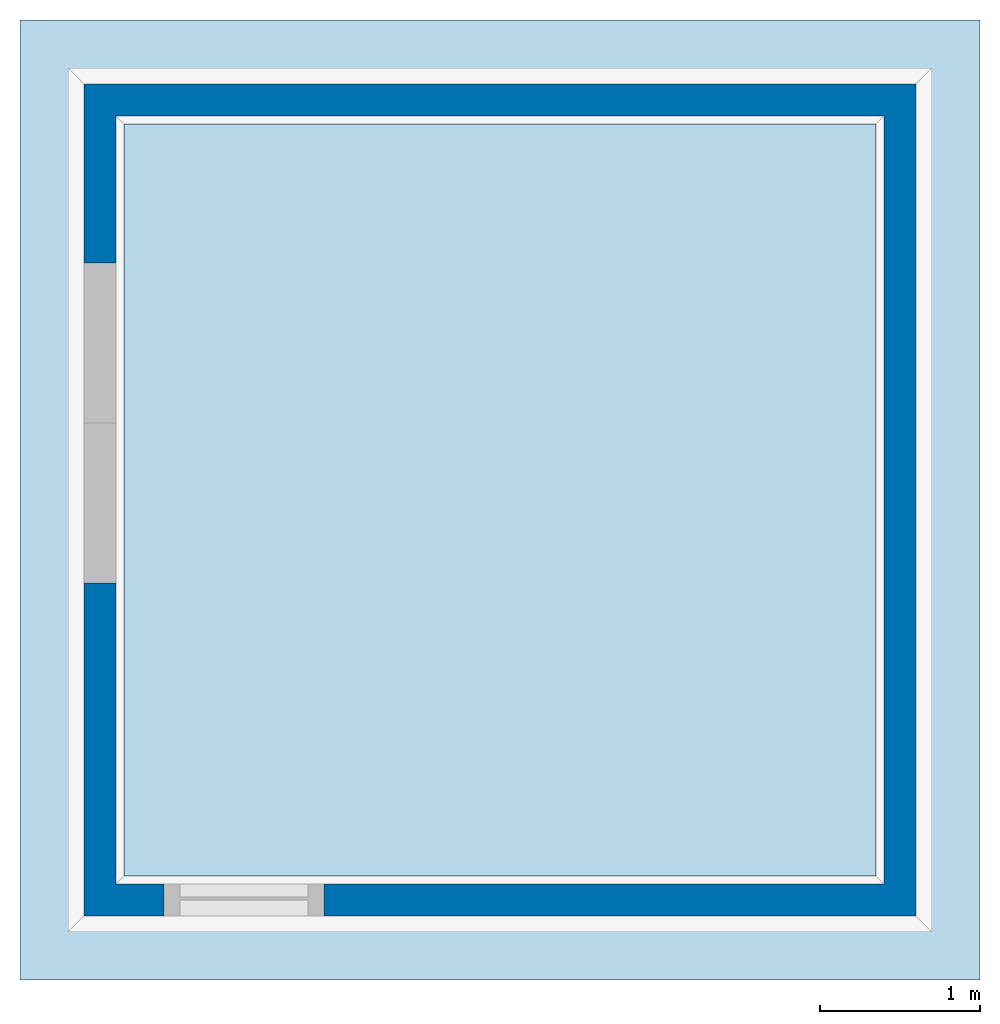
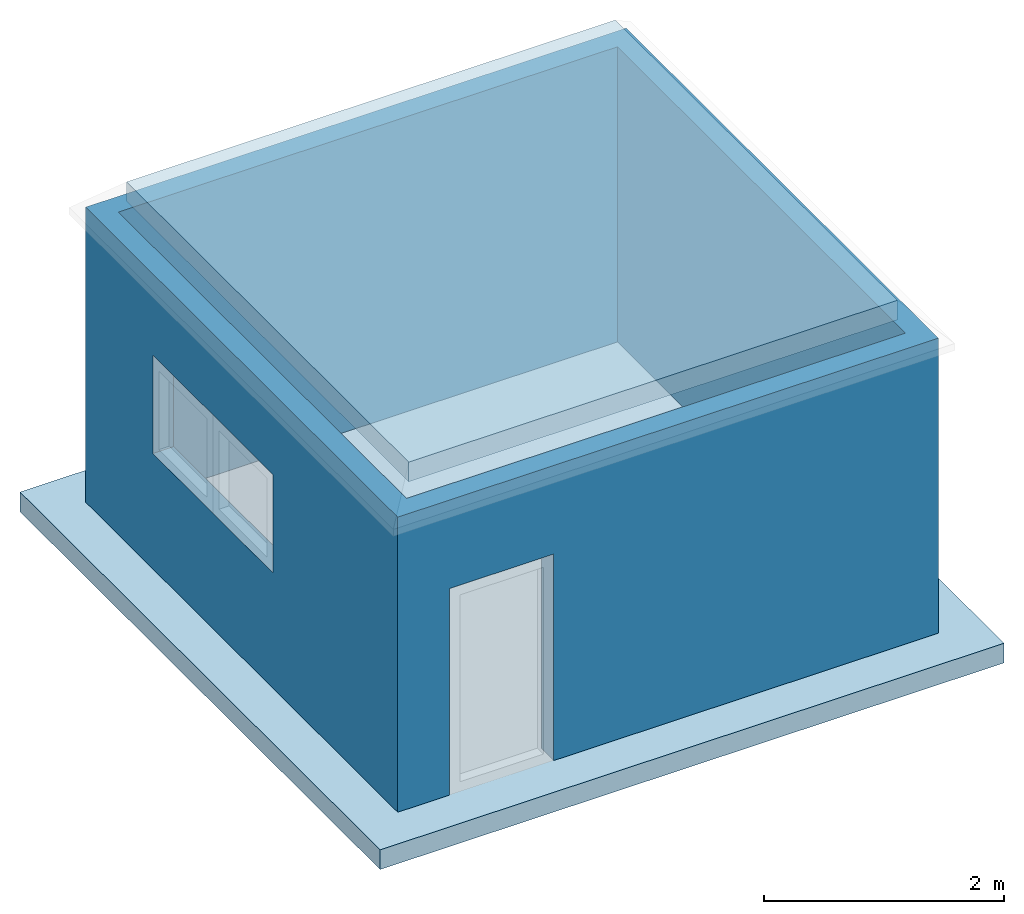
# Not in any storey, part 1 of 3: 2 slabs, 1 wall, 3 openings.
"""IFC4 building model written with IfcOpenShell, lengths in metres."""

from ifc_helpers import new_model, entity, si_unit, converted_unit, direction, frame, origin_with_axes, origin_2d_with_axis, place, context, subcontext, project, spatial, polyline, rectangle, outline, extrude, faceted_brep, element, save


model = new_model("IFC4")

# Units and contexts
model_context = context("Model", 3, precision=1e-05, world=origin_with_axes(), true_north=direction((0.0, 1.0)))
body_context = subcontext(model_context, "Body", "Model", "MODEL_VIEW")
ifc_project = project(units=[si_unit("LENGTHUNIT", "METRE"), si_unit("AREAUNIT", "SQUARE_METRE"), si_unit("VOLUMEUNIT", "CUBIC_METRE"), converted_unit("PLANEANGLEUNIT", "DEGREE", entity("IfcPlaneAngleMeasure", 0.017453292519943295), si_unit("PLANEANGLEUNIT", "RADIAN"), dimensions=[0, 0, 0, 0, 0, 0, 0])], contexts=[model_context])

# Building
building = spatial("IfcBuilding", CompositionType="COMPLEX")

# Slabs
placement = place(None, origin_with_axes())
element("IfcSlab", 1, at=placement, inside=building, Name="Slab", PredefinedType="FLOOR", context=body_context, shape_type="SweptSolid", body=[
    extrude(rectangle(XDim=6.0, YDim=6.0, at=origin_2d_with_axis()), frame((2.5, 2.5, -0.2), z_axis=(0.0, 0.0, 1.0), x_axis=(1.0, 0.0, 0.0)), (0.0, 0.0, 1.0), 0.2),
])
element("IfcSlab", 2, at=placement, inside=building, Name="Slab001", PredefinedType="FLOOR", context=body_context, shape_type="SweptSolid", body=[
    extrude(rectangle(XDim=4.7, YDim=4.7, at=origin_2d_with_axis()), frame((2.5, 2.5, 3.321), z_axis=(0.0, 0.0, 1.0), x_axis=(1.0, 0.0, 0.0)), (0.0, 0.0, -1.0), 0.2),
])

# Wall, openings
wall = element("IfcWall", 3, at=placement, inside=building, Name="Wall", PredefinedType="MOVABLE", context=body_context, shape_type="SweptSolid", body=[
    extrude(outline(polyline([(2.6, 2.6), (-2.6, 2.6), (-2.6, -2.6), (2.6, -2.6), (2.6, 2.6)]), holes=[polyline([(-2.4, -2.4), (2.4, -2.4), (2.4, 2.4), (-2.4, 2.4), (-2.4, -2.4)])]), frame((2.5, 2.5, 0.0), z_axis=(0.0, 0.0, 1.0), x_axis=(1.0, 0.0, 0.0)), (0.0, 0.0, 1.0), 3.0),
])
element("IfcOpeningElement", 4, at=placement, cuts=wall, context=body_context, shape_type="Brep", body=[
    faceted_brep([(0.9, 2.9806728515625, 1.17355590820313), (-1.1, 2.9806728515625, 1.17355590820313), (-1.1, 3.9806728515625, 1.17355590820313), (0.9, 3.9806728515625, 1.17355590820313), (0.9, 2.9806728515625, 2.17355590820313), (-1.1, 2.9806728515625, 2.17355590820313), (0.9, 3.9806728515625, 2.17355590820313), (-1.1, 3.9806728515625, 2.17355590820313)], [[[0, 1, 2, 3]], [[4, 5, 1, 0]], [[6, 7, 5, 4]], [[3, 2, 7, 6]], [[6, 4, 0, 3]], [[2, 1, 5, 7]]]),
])
element("IfcOpeningElement", 5, at=placement, cuts=wall, Name="001", context=body_context, shape_type="Brep", body=[
    faceted_brep([(0.9, 1.9806728515625, 1.17355590820313), (-1.1, 1.9806728515625, 1.17355590820313), (-1.1, 2.9806728515625, 1.17355590820313), (0.9, 2.9806728515625, 1.17355590820313), (0.9, 1.9806728515625, 2.17355590820313), (-1.1, 1.9806728515625, 2.17355590820313), (0.9, 2.9806728515625, 2.17355590820313), (-1.1, 2.9806728515625, 2.17355590820313)], [[[0, 1, 2, 3]], [[4, 5, 1, 0]], [[6, 7, 5, 4]], [[3, 2, 7, 6]], [[6, 4, 0, 3]], [[2, 1, 5, 7]]]),
])
element("IfcOpeningElement", 6, at=placement, cuts=wall, Name="002", context=body_context, shape_type="Brep", body=[
    faceted_brep([(1.4, 2.0, -4.2e-16), (1.4, -2.2, 4.2e-16), (0.4, -2.2, 4.2e-16), (0.4, 2.0, -4.2e-16), (1.4, 2.0, 2.1), (1.4, -2.2, 2.1), (0.4, 2.0, 2.1), (0.4, -2.2, 2.1)], [[[0, 1, 2, 3]], [[4, 5, 1, 0]], [[6, 7, 5, 4]], [[3, 2, 7, 6]], [[6, 4, 0, 3]], [[2, 1, 5, 7]]]),
])

save(model, "model.ifc")
